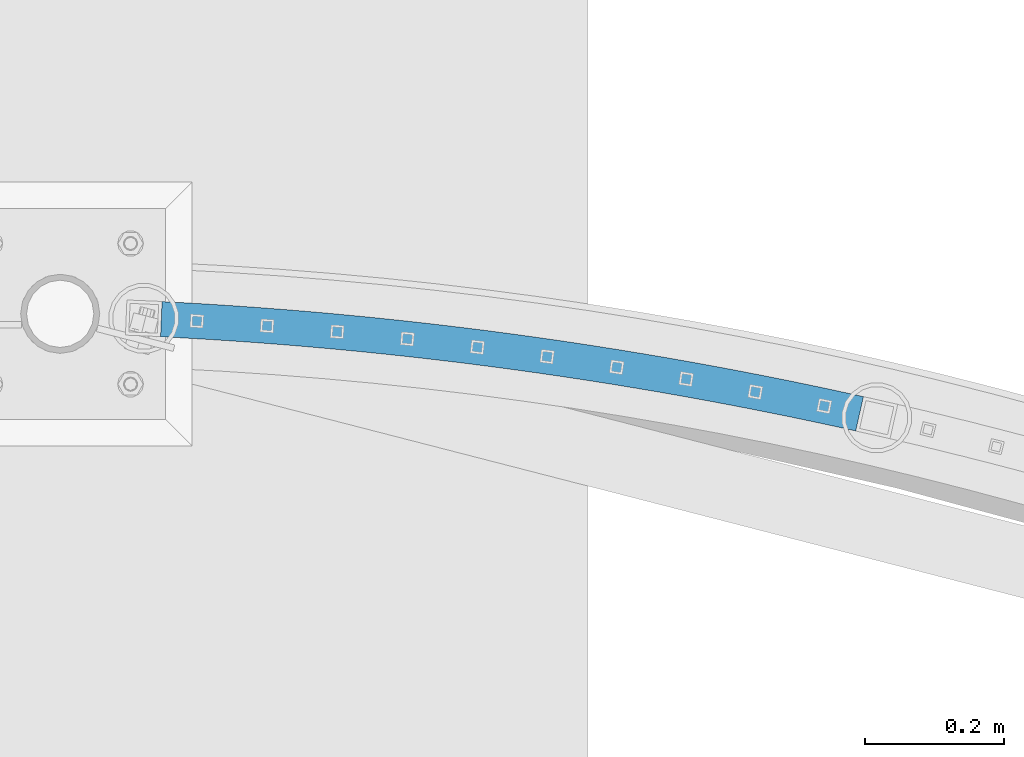
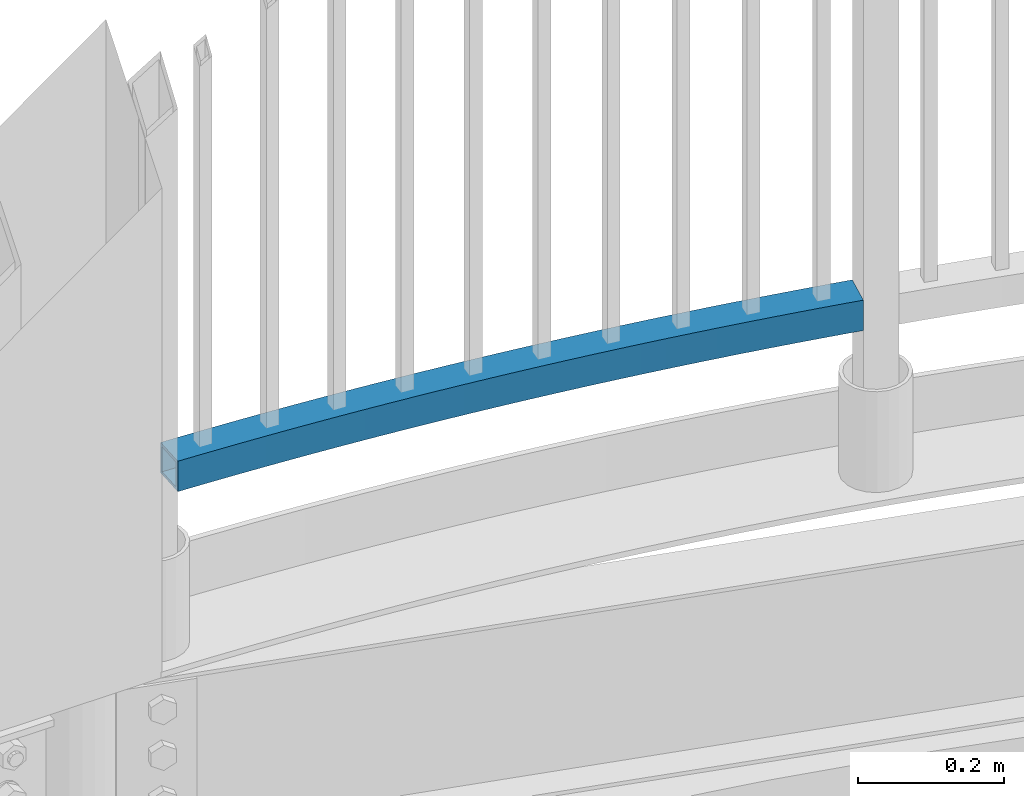
# One storey, part 328 of 975: 1 beam.
"""IFC2X3 building model written with IfcOpenShell, lengths in millimetres."""

from ifc_helpers import new_model, si_unit, frame, origin_with_axes, place, context, subcontext, project, spatial, faceted_brep, material, type_object, element, save


model = new_model("IFC2X3")

# Units and contexts
model_context = context("Model", 3, precision=1e-05, world=origin_with_axes())
body_context = subcontext(model_context, "Body", "Model", "MODEL_VIEW")
ifc_project = project(units=[si_unit("LENGTHUNIT", "METRE", prefix="MILLI"), si_unit("AREAUNIT", "SQUARE_METRE"), si_unit("VOLUMEUNIT", "CUBIC_METRE"), si_unit("MASSUNIT", "GRAM", prefix="KILO"), si_unit("TIMEUNIT", "SECOND"), si_unit("PLANEANGLEUNIT", "RADIAN"), si_unit("SOLIDANGLEUNIT", "STERADIAN"), si_unit("THERMODYNAMICTEMPERATUREUNIT", "DEGREE_CELSIUS"), si_unit("LUMINOUSINTENSITYUNIT", "LUMEN")], contexts=[model_context])

# Site, building, storey
site_placement = place(None, origin_with_axes())
site = spatial("IfcSite", under=ifc_project, at=site_placement, CompositionType="ELEMENT")
building_placement = place(site_placement, origin_with_axes())
building = spatial("IfcBuilding", under=site, at=building_placement, Name="Undefined", CompositionType="ELEMENT")
storey_placement = place(building_placement, origin_with_axes())
storey = spatial("IfcBuildingStorey", under=building, at=storey_placement, Name="Undefined", CompositionType="ELEMENT", Elevation=0.0)

# Beam
ifc_material = material()
beam_type = type_object("IfcBeamType", Name="HSS2X2X.188_TUBES", PredefinedType="NOTDEFINED")
beam_placement = place(storey_placement, frame((16519.5331439159, 29957.1361658595, 4229.10000192006), z_axis=(0.0, 0.0, 1.0), x_axis=(0.975010716016224, -0.222157835003697, 0.0)))
element("IfcBeam", 1, at=beam_placement, inside=storey, type_object=beam_type, material=ifc_material, Name="GUARDRAIL", ObjectType="HSS2X2X.188_TUBES", context=body_context, shape_type="Brep", body=[
    faceted_brep([(1001.29951082957, 73.7247533809277, 25.3999999999996), (1001.29951082957, 73.7247533809277, -25.3999999999996), (1038.43502130654, 74.1829823261942, -25.3999999999996), (1038.43502130654, 74.1829823261942, 25.3999999999996), (964.167534028617, 73.0374317639726, 25.3999999999996), (964.167534028617, 73.0374317639726, -25.3999999999996), (927.040504185796, 72.1210436355032, 25.3999999999996), (927.040504185796, 72.1210436355032, -25.3999999999996), (889.919834394939, 70.975623874212, 25.3999999999996), (889.919834394939, 70.975623874212, -25.3999999999996), (852.806937507794, 69.6012160759929, 25.3999999999996), (852.806937507794, 69.6012160759929, -25.3999999999996), (815.703226080273, 67.9978725522524, 25.3999999999996), (815.703226080273, 67.9978725522524, -25.3999999999996), (778.610112318689, 66.1656543279241, 25.3999999999996), (778.610112318689, 66.1656543279241, -25.3999999999996), (741.529008025978, 64.1046311391619, 25.3999999999996), (741.529008025978, 64.1046311391619, -25.3999999999996), (704.461324547996, 61.8148814306842, 25.3999999999996), (704.461324547996, 61.8148814306842, -25.3999999999996), (667.408472719777, 59.2964923527688, 25.3999999999996), (667.408472719777, 59.2964923527688, -25.3999999999996), (630.37186281186, 56.5495597579575, 25.3999999999996), (630.37186281186, 56.5495597579575, -25.3999999999996), (593.352904476596, 53.5741881973954, 25.3999999999996), (593.352904476596, 53.5741881973954, -25.3999999999996), (556.353006694488, 50.3704909168591, 25.3999999999996), (556.353006694488, 50.3704909168591, -25.3999999999996), (519.373577720591, 46.9385898524197, 25.3999999999996), (519.373577720591, 46.9385898524197, -25.3999999999996), (482.416025030883, 43.2786156258735, 25.3999999999996), (482.416025030883, 43.2786156258735, -25.3999999999996), (445.481755268713, 39.3907075396637, 25.3999999999996), (445.481755268713, 39.3907075396637, -25.3999999999996), (408.572174191255, 35.2750135716778, 25.3999999999996), (408.572174191255, 35.2750135716778, -25.3999999999996), (371.688686616004, 30.9316903695581, 25.3999999999996), (371.688686616004, 30.9316903695581, -25.3999999999996), (334.832696367317, 26.3609032447494, 25.3999999999996), (334.832696367317, 26.3609032447494, -25.3999999999996), (298.005606222967, 21.562826166235, 25.3999999999996), (298.005606222967, 21.562826166235, -25.3999999999996), (261.208817860759, 16.5376417538646, 25.3999999999996), (261.208817860759, 16.5376417538646, -25.3999999999996), (224.443731805179, 11.2855412714489, 25.3999999999996), (224.443731805179, 11.2855412714489, -25.3999999999996), (187.711747374095, 5.80672461944778, 25.3999999999996), (187.711747374095, 5.80672461944778, -25.3999999999996), (151.014262625486, 0.101400327410374, 25.3999999999996), (151.014262625486, 0.101400327410374, -25.3999999999996), (114.352674304246, -5.83021445403574, 25.3999999999996), (114.352674304246, -5.83021445403574, -25.3999999999996), (77.7283777890043, -11.98789396137, 25.3999999999996), (77.7283777890043, -11.98789396137, -25.3999999999996), (54.6006013976294, -16.0232615754285, 25.3999999999996), (54.6006013976294, -16.0232615754285, -25.3999999999996), (69.1510491560402, 38.0827504675835, 25.3999999999996), (69.1510491560402, 38.0827504675835, -25.3999999999996), (45.4057823300282, 33.9396422363716, -25.3999999999996), (45.4057823300282, 33.9396422363716, 25.3999999999996), (106.084411464662, 44.2923935150757, 25.3999999999996), (106.084411464662, 44.2923935150757, -25.3999999999996), (143.055380278063, 50.2740641174532, 25.3999999999996), (143.055380278063, 50.2740641174532, -25.3999999999996), (180.062548442271, 56.0275346060516, 25.3999999999996), (180.062548442271, 56.0275346060516, -25.3999999999996), (217.104507425516, 61.5525859977206, 25.3999999999996), (217.104507425516, 61.5525859977206, -25.3999999999996), (254.179847371863, 66.8490080031988, 25.3999999999996), (254.179847371863, 66.8490080031988, -25.3999999999996), (291.287157154849, 71.9165990350884, 25.3999999999996), (291.287157154849, 71.9165990350884, -25.3999999999996), (328.425024431219, 76.7551662155383, 25.3999999999996), (328.425024431219, 76.7551662155383, -25.3999999999996), (365.592035694661, 81.3645253835857, 25.3999999999996), (365.592035694661, 81.3645253835857, -25.3999999999996), (402.786776329616, 85.7445011021773, 25.3999999999996), (402.786776329616, 85.7445011021773, -25.3999999999996), (440.007830665116, 89.8949266648342, 25.3999999999996), (440.007830665116, 89.8949266648342, -25.3999999999996), (477.253782028651, 93.8156441019746, 25.3999999999996), (477.253782028651, 93.8156441019746, -25.3999999999996), (514.523212800133, 97.5065041869821, 25.3999999999996), (514.523212800133, 97.5065041869821, -25.3999999999996), (551.814704465793, 100.96736644183, 25.3999999999996), (551.814704465793, 100.96736644183, -25.3999999999996), (589.126837672218, 104.198099142457, 25.3999999999996), (589.126837672218, 104.198099142457, -25.3999999999996), (626.458192280355, 107.198579323784, 25.3999999999996), (626.458192280355, 107.198579323784, -25.3999999999996), (663.807347419561, 109.968692784372, 25.3999999999996), (663.807347419561, 109.968692784372, -25.3999999999996), (701.17288154169, 112.508334090795, 25.3999999999996), (701.17288154169, 112.508334090795, -25.3999999999996), (738.553372475184, 114.817406581627, 25.3999999999996), (738.553372475184, 114.817406581627, -25.3999999999996), (775.947397479227, 116.895822371131, 25.3999999999996), (775.947397479227, 116.895822371131, -25.3999999999996), (813.353533297874, 118.743502352634, 25.3999999999996), (813.353533297874, 118.743502352634, -25.3999999999996), (850.770356214231, 120.360376201468, 25.3999999999996), (850.770356214231, 120.360376201468, -25.3999999999996), (888.196442104643, 121.746382377729, 25.3999999999996), (888.196442104643, 121.746382377729, -25.3999999999996), (925.630366492889, 122.901468128563, 25.3999999999996), (925.630366492889, 122.901468128563, -25.3999999999996), (963.070704604426, 123.825589490189, 25.3999999999996), (963.070704604426, 123.825589490189, -25.3999999999996), (1000.51603142058, 124.518711289566, 25.3999999999996), (1000.51603142058, 124.518711289566, -25.3999999999996), (1037.9649217328, 124.980807145759, 25.3999999999996), (1037.9649217328, 124.980807145759, -25.3999999999996), (1063.33452829664, 125.137323717543, 25.3999999999996), (1063.33452829664, 125.137323717543, -25.3999999999996), (1063.4834169918, 74.3375172028536, -25.3999999999996), (1063.4834169918, 74.3375172028536, 25.3999999999996), (1000.58948261517, 119.756777735631, 20.6374999999998), (1000.58948261517, 119.756777735631, -20.6374999999998), (1038.00899356784, 120.218511068924, -20.6374999999998), (1038.00899356784, 120.218511068924, 20.6374999999998), (963.173532362944, 119.06419970336, 20.6374999999998), (963.173532362944, 119.06419970336, -20.6374999999998), (925.762566901602, 118.140803332339, 20.6374999999998), (925.762566901602, 118.140803332339, -20.6374999999998), (888.358010131855, 116.986623768025, 20.6374999999998), (888.358010131855, 116.986623768025, -20.6374999999998), (850.9612857105, 115.601704939712, 20.6374999999998), (850.9612857105, 115.601704939712, -20.6374999999998), (813.573816996221, 113.986099558846, 20.6374999999998), (813.573816996221, 113.986099558846, -20.6374999999998), (776.197026995425, 112.139869117083, 20.6374999999998), (776.197026995425, 112.139869117083, -20.6374999999998), (738.832338308073, 110.063083883892, 20.6374999999998), (738.832338308073, 110.063083883892, -20.6374999999998), (701.481173073531, 107.755822903913, 20.6374999999998), (701.481173073531, 107.755822903913, -20.6374999999998), (664.144952916458, 105.218173993911, 20.6374999999998), (664.144952916458, 105.218173993911, -20.6374999999998), (626.825098892685, 102.450233739488, 20.6374999999998), (626.825098892685, 102.450233739488, -20.6374999999998), (589.523031435128, 99.4521074913573, 20.6374999999998), (589.523031435128, 99.4521074913573, -20.6374999999998), (552.240170299734, 96.2239093613607, 20.6374999999998), (552.240170299734, 96.2239093613607, -20.6374999999998), (514.977934511426, 92.7657622181141, 20.6374999999998), (514.977934511426, 92.7657622181141, -20.6374999999998), (477.73774231011, 89.0777976823374, 20.6374999999998), (477.73774231011, 89.0777976823374, -20.6374999999998), (440.5210110967, 85.1601561218486, 20.6374999999998), (440.5210110967, 85.1601561218486, -20.6374999999998), (403.329157379147, 81.0129866461939, 20.6374999999998), (403.329157379147, 81.0129866461939, -20.6374999999998), (366.163596718539, 76.6364471010238, 20.6374999999998), (366.163596718539, 76.6364471010238, -20.6374999999998), (329.025743675227, 72.0307040620246, 20.6374999999998), (329.025743675227, 72.0307040620246, -20.6374999999998), (291.917011754984, 67.1959328286321, 20.6374999999998), (291.917011754984, 67.1959328286321, -20.6374999999998), (254.838813355194, 62.1323174173231, 20.6374999999998), (254.838813355194, 62.1323174173231, -20.6374999999998), (217.792559711113, 56.8400505546379, 20.6374999999998), (217.792559711113, 56.8400505546379, -20.6374999999998), (180.779660842129, 51.3193336698096, 20.6374999999998), (180.779660842129, 51.3193336698096, -20.6374999999998), (143.801525498133, 45.570376887139, 20.6374999999998), (143.801525498133, 45.570376887139, -20.6374999999998), (106.859561105874, 39.5933990179692, 20.6374999999998), (106.859561105874, 39.5933990179692, -20.6374999999998), (69.9551737153797, 33.3886275523764, 20.6374999999998), (69.9551737153797, 33.3886275523764, -20.6374999999998), (46.2677966176125, 29.2556200040199, 20.6374999999998), (46.2677966176125, 29.2556200040199, -20.6374999999998), (53.738587110045, -11.3392393430695, 20.6374999999998), (53.738587110045, -11.3392393430695, -20.6374999999998), (76.924253229663, -7.2937710461556, 20.6374999999998), (76.924253229663, -7.2937710461556, -20.6374999999998), (113.577524663036, -1.13121995692927, 20.6374999999998), (113.577524663036, -1.13121995692927, -20.6374999999998), (150.268117405416, 4.80508755772462, 20.6374999999998), (150.268117405416, 4.80508755772462, -20.6374999999998), (186.994634974235, 10.5149255556898, 20.6374999999998), (186.994634974235, 10.5149255556898, -20.6374999999998), (223.755679519585, 15.9980767145316, 20.6374999999998), (223.755679519585, 15.9980767145316, -20.6374999999998), (260.549851877422, 21.2543323397404, 20.6374999999998), (260.549851877422, 21.2543323397404, -20.6374999999998), (297.375751622832, 26.2834923726841, 20.6374999999998), (297.375751622832, 26.2834923726841, -20.6374999999998), (334.231977123309, 31.0853653982631, 20.6374999999998), (334.231977123309, 31.0853653982631, -20.6374999999998), (371.117125592133, 35.6597686521272, 20.6374999999998), (371.117125592133, 35.6597686521272, -20.6374999999998), (408.029793141726, 40.0065280276613, 20.6374999999998), (408.029793141726, 40.0065280276613, -20.6374999999998), (444.968574837123, 44.1254780826494, 20.6374999999998), (444.968574837123, 44.1254780826494, -20.6374999999998), (481.932064749424, 48.0164620455034, 20.6374999999998), (481.932064749424, 48.0164620455034, -20.6374999999998), (518.918856009299, 51.6793318212876, 20.6374999999998), (518.918856009299, 51.6793318212876, -20.6374999999998), (555.92754086055, 55.1139479973208, 20.6374999999998), (555.92754086055, 55.1139479973208, -20.6374999999998), (592.956710713686, 58.3201798484952, 20.6374999999998), (592.956710713686, 58.3201798484952, -20.6374999999998), (630.004956199529, 61.2979053422532, 20.6374999999998), (630.004956199529, 61.2979053422532, -20.6374999999998), (667.070867222879, 64.0470111432296, 20.6374999999998), (667.070867222879, 64.0470111432296, -20.6374999999998), (704.153033016151, 66.5673926175659, 20.6374999999998), (704.153033016151, 66.5673926175659, -20.6374999999998), (741.250042193093, 68.8589538368906, 20.6374999999998), (741.250042193093, 68.8589538368906, -20.6374999999998), (778.360482802491, 70.9216075819713, 20.6374999999998), (778.360482802491, 70.9216075819713, -20.6374999999998), (815.482942381925, 72.7552753460332, 20.6374999999998), (815.482942381925, 72.7552753460332, -20.6374999999998), (852.616008011522, 74.3598873377559, 20.6374999999998), (852.616008011522, 74.3598873377559, -20.6374999999998), (889.758266367722, 75.7353824839156, 20.6374999999998), (889.758266367722, 75.7353824839156, -20.6374999999998), (926.908303777089, 76.881708431727, 20.6374999999998), (926.908303777089, 76.881708431727, -20.6374999999998), (964.064706270099, 77.7988215508012, 20.6374999999998), (964.064706270099, 77.7988215508012, -20.6374999999998), (1001.22605963498, 78.4866869348625, 20.6374999999998), (1001.22605963498, 78.4866869348625, -20.6374999999998), (1038.3909494715, 78.9452784030291, 20.6374999999998), (1038.3909494715, 78.9452784030291, -20.6374999999998), (1063.46945867662, 79.0999990636046, 20.6374999999998), (1063.46945867662, 79.0999990636046, -20.6374999999998), (1063.34848661181, 120.374841856792, -20.6374999999998), (1063.34848661181, 120.374841856792, 20.6374999999998)], [[[0, 1, 2, 3]], [[4, 5, 1, 0]], [[6, 7, 5, 4]], [[8, 9, 7, 6]], [[10, 11, 9, 8]], [[12, 13, 11, 10]], [[14, 15, 13, 12]], [[16, 17, 15, 14]], [[18, 19, 17, 16]], [[20, 21, 19, 18]], [[22, 23, 21, 20]], [[24, 25, 23, 22]], [[26, 27, 25, 24]], [[28, 29, 27, 26]], [[30, 31, 29, 28]], [[32, 33, 31, 30]], [[34, 35, 33, 32]], [[36, 37, 35, 34]], [[38, 39, 37, 36]], [[40, 41, 39, 38]], [[42, 43, 41, 40]], [[44, 45, 43, 42]], [[46, 47, 45, 44]], [[48, 49, 47, 46]], [[50, 51, 49, 48]], [[52, 53, 51, 50]], [[53, 52, 54, 55]], [[56, 57, 58, 59]], [[57, 56, 60, 61]], [[61, 60, 62, 63]], [[63, 62, 64, 65]], [[65, 64, 66, 67]], [[67, 66, 68, 69]], [[69, 68, 70, 71]], [[71, 70, 72, 73]], [[73, 72, 74, 75]], [[75, 74, 76, 77]], [[77, 76, 78, 79]], [[79, 78, 80, 81]], [[81, 80, 82, 83]], [[83, 82, 84, 85]], [[85, 84, 86, 87]], [[87, 86, 88, 89]], [[89, 88, 90, 91]], [[91, 90, 92, 93]], [[93, 92, 94, 95]], [[95, 94, 96, 97]], [[97, 96, 98, 99]], [[99, 98, 100, 101]], [[101, 100, 102, 103]], [[103, 102, 104, 105]], [[105, 104, 106, 107]], [[107, 106, 108, 109]], [[109, 108, 110, 111]], [[111, 110, 112, 113]], [[2, 1, 5, 7, 9, 11, 13, 15, 17, 19, 21, 23, 25, 27, 29, 31, 33, 35, 37, 39, 41, 43, 45, 47, 49, 51, 53, 55, 58, 57, 61, 63, 65, 67, 69, 71, 73, 75, 77, 79, 81, 83, 85, 87, 89, 91, 93, 95, 97, 99, 101, 103, 105, 107, 109, 111, 113, 114]], [[3, 2, 114, 115]], [[110, 108, 106, 104, 102, 100, 98, 96, 94, 92, 90, 88, 86, 84, 82, 80, 78, 76, 74, 72, 70, 68, 66, 64, 62, 60, 56, 59, 54, 52, 50, 48, 46, 44, 42, 40, 38, 36, 34, 32, 30, 28, 26, 24, 22, 20, 18, 16, 14, 12, 10, 8, 6, 4, 0, 3, 115, 112]], [[116, 117, 118, 119]], [[120, 121, 117, 116]], [[122, 123, 121, 120]], [[124, 125, 123, 122]], [[126, 127, 125, 124]], [[128, 129, 127, 126]], [[130, 131, 129, 128]], [[132, 133, 131, 130]], [[134, 135, 133, 132]], [[136, 137, 135, 134]], [[138, 139, 137, 136]], [[140, 141, 139, 138]], [[142, 143, 141, 140]], [[144, 145, 143, 142]], [[146, 147, 145, 144]], [[148, 149, 147, 146]], [[150, 151, 149, 148]], [[152, 153, 151, 150]], [[154, 155, 153, 152]], [[156, 157, 155, 154]], [[158, 159, 157, 156]], [[160, 161, 159, 158]], [[162, 163, 161, 160]], [[164, 165, 163, 162]], [[166, 167, 165, 164]], [[168, 169, 167, 166]], [[169, 168, 170, 171]], [[58, 55, 54, 59], [171, 170, 172, 173]], [[174, 175, 173, 172]], [[175, 174, 176, 177]], [[177, 176, 178, 179]], [[179, 178, 180, 181]], [[181, 180, 182, 183]], [[183, 182, 184, 185]], [[185, 184, 186, 187]], [[187, 186, 188, 189]], [[189, 188, 190, 191]], [[191, 190, 192, 193]], [[193, 192, 194, 195]], [[195, 194, 196, 197]], [[197, 196, 198, 199]], [[199, 198, 200, 201]], [[201, 200, 202, 203]], [[203, 202, 204, 205]], [[205, 204, 206, 207]], [[207, 206, 208, 209]], [[209, 208, 210, 211]], [[211, 210, 212, 213]], [[213, 212, 214, 215]], [[215, 214, 216, 217]], [[217, 216, 218, 219]], [[219, 218, 220, 221]], [[221, 220, 222, 223]], [[223, 222, 224, 225]], [[225, 224, 226, 227]], [[227, 226, 228, 229]], [[118, 117, 121, 123, 125, 127, 129, 131, 133, 135, 137, 139, 141, 143, 145, 147, 149, 151, 153, 155, 157, 159, 161, 163, 165, 167, 169, 171, 173, 175, 177, 179, 181, 183, 185, 187, 189, 191, 193, 195, 197, 199, 201, 203, 205, 207, 209, 211, 213, 215, 217, 219, 221, 223, 225, 227, 229, 230]], [[119, 118, 230, 231]], [[226, 224, 222, 220, 218, 216, 214, 212, 210, 208, 206, 204, 202, 200, 198, 196, 194, 192, 190, 188, 186, 184, 182, 180, 178, 176, 174, 172, 170, 168, 166, 164, 162, 160, 158, 156, 154, 152, 150, 148, 146, 144, 142, 140, 138, 136, 134, 132, 130, 128, 126, 124, 122, 120, 116, 119, 231, 228]], [[113, 112, 115, 114], [230, 229, 228, 231]]]),
])

save(model, "model.ifc")
